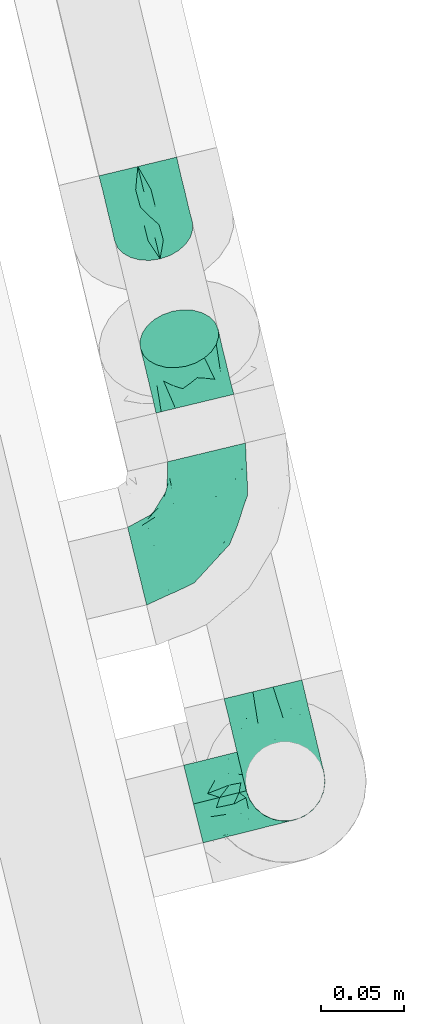
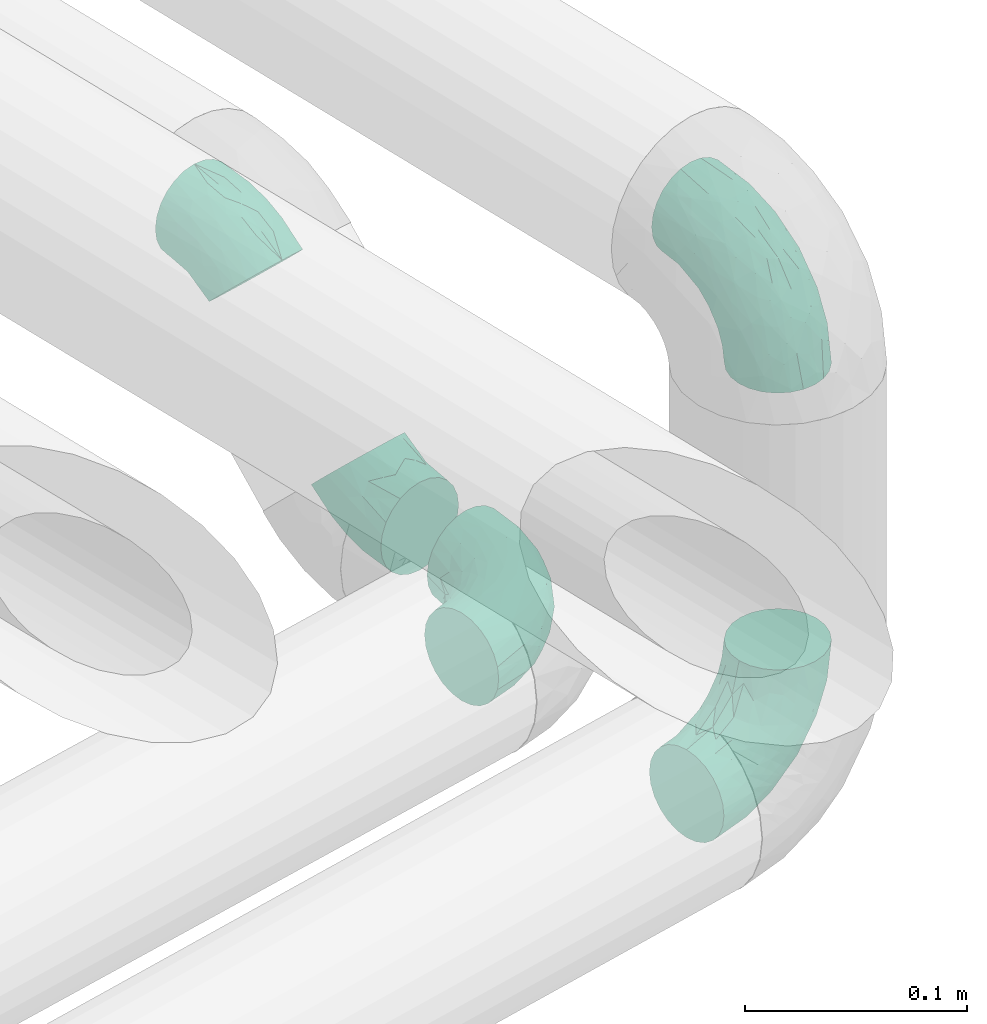
# One storey, part 50 of 93: 5 flow fittings.
"""IFC2X3 building model written with IfcOpenShell, lengths in millimetres."""

from ifc_helpers import new_model, entity, si_unit, converted_unit, derived_unit, direction, frame, origin, place, context, subcontext, project, spatial, faceted_brep, source, transform, mapped, material, type_object, type_shapes, element, save


model = new_model("IFC2X3")

# Units and contexts
model_context = context("Model", 3, precision=0.01, world=origin(), true_north=direction((6.12303176911189e-17, 1.0)))
body_context = subcontext(model_context, "Body", "Model", "MODEL_VIEW")
ifc_project = project(units=[si_unit("LENGTHUNIT", "METRE", prefix="MILLI"), si_unit("AREAUNIT", "SQUARE_METRE"), si_unit("VOLUMEUNIT", "CUBIC_METRE"), converted_unit("PLANEANGLEUNIT", "DEGREE", entity("IfcRatioMeasure", 0.0174532925199433), si_unit("PLANEANGLEUNIT", "RADIAN"), dimensions=[0, 0, 0, 0, 0, 0, 0]), si_unit("MASSUNIT", "GRAM", prefix="KILO"), derived_unit("MASSDENSITYUNIT", [(si_unit("MASSUNIT", "GRAM", prefix="KILO"), 1), (si_unit("LENGTHUNIT", "METRE"), -3)]), derived_unit("MOMENTOFINERTIAUNIT", [(si_unit("LENGTHUNIT", "METRE"), 4)]), si_unit("TIMEUNIT", "SECOND"), si_unit("FREQUENCYUNIT", "HERTZ"), si_unit("THERMODYNAMICTEMPERATUREUNIT", "DEGREE_CELSIUS"), derived_unit("THERMALTRANSMITTANCEUNIT", [(si_unit("MASSUNIT", "GRAM", prefix="KILO"), 1), (si_unit("THERMODYNAMICTEMPERATUREUNIT", "KELVIN"), -1), (si_unit("TIMEUNIT", "SECOND"), -3)]), derived_unit("VOLUMETRICFLOWRATEUNIT", [(si_unit("LENGTHUNIT", "METRE"), 3), (si_unit("TIMEUNIT", "SECOND"), -1)]), derived_unit("MASSFLOWRATEUNIT", [(si_unit("MASSUNIT", "GRAM", prefix="KILO"), 1), (si_unit("TIMEUNIT", "SECOND"), -1)]), derived_unit("ROTATIONALFREQUENCYUNIT", [(si_unit("TIMEUNIT", "SECOND"), -1)]), si_unit("ELECTRICCURRENTUNIT", "AMPERE"), si_unit("ELECTRICVOLTAGEUNIT", "VOLT"), si_unit("POWERUNIT", "WATT"), si_unit("FORCEUNIT", "NEWTON", prefix="KILO"), si_unit("ILLUMINANCEUNIT", "LUX"), si_unit("LUMINOUSFLUXUNIT", "LUMEN"), si_unit("LUMINOUSINTENSITYUNIT", "CANDELA"), derived_unit("USERDEFINED", [(si_unit("MASSUNIT", "GRAM", prefix="KILO"), -1), (si_unit("LENGTHUNIT", "METRE"), -2), (si_unit("TIMEUNIT", "SECOND"), 3), (si_unit("LUMINOUSFLUXUNIT", "LUMEN"), 1)]), derived_unit("LINEARVELOCITYUNIT", [(si_unit("LENGTHUNIT", "METRE"), 1), (si_unit("TIMEUNIT", "SECOND"), -1)]), si_unit("PRESSUREUNIT", "PASCAL"), derived_unit("USERDEFINED", [(si_unit("LENGTHUNIT", "METRE"), -2), (si_unit("MASSUNIT", "GRAM", prefix="KILO"), 1), (si_unit("TIMEUNIT", "SECOND"), -2)]), derived_unit("LINEARFORCEUNIT", [(si_unit("MASSUNIT", "GRAM", prefix="KILO"), 1), (si_unit("LENGTHUNIT", "METRE"), 1), (si_unit("TIMEUNIT", "SECOND"), -2), (si_unit("LENGTHUNIT", "METRE"), -1)]), derived_unit("PLANARFORCEUNIT", [(si_unit("MASSUNIT", "GRAM", prefix="KILO"), 1), (si_unit("LENGTHUNIT", "METRE"), 1), (si_unit("TIMEUNIT", "SECOND"), -2), (si_unit("LENGTHUNIT", "METRE"), -2)])], contexts=[model_context])

# Site, building, storey
site_placement = place(None, origin())
site = spatial("IfcSite", under=ifc_project, at=site_placement, CompositionType="ELEMENT")
building_placement = place(site_placement, origin())
building = spatial("IfcBuilding", under=site, at=building_placement, CompositionType="ELEMENT")
storey_placement = place(building_placement, frame((0.0, 0.0, -4200.0)))
storey = spatial("IfcBuildingStorey", under=building, at=storey_placement, CompositionType="ELEMENT", Elevation=-4200.0)

# Flow fittings
ifc_material = material()
pipe_fitting_type_1 = type_object("IfcPipeFittingType", Name="ADSK_1", PredefinedType="NOTDEFINED", material=ifc_material)
shared_shape_1 = source(origin(), body_context, "Body", "Brep", [
    faceted_brep([(-23.61, 12.07, -20.91), (-23.61, 6.25, -23.33), (-23.61, 0.0, -24.15), (-23.61, -6.25, -23.33), (-23.61, -12.08, -20.91), (-23.61, -17.08, -17.08), (-23.61, -20.91, -12.08), (-23.61, -23.33, -6.25), (-23.61, -24.15, 0.0), (-23.61, -23.33, 6.25), (-23.61, -20.91, 12.07), (-23.61, -17.08, 17.08), (-23.61, -12.08, 20.91), (-23.61, -6.25, 23.33), (-23.61, 0.0, 24.15), (-23.61, 6.25, 23.33), (-23.61, 12.07, 20.91), (-23.61, 17.08, 17.08), (-23.61, 20.91, 12.07), (-23.61, 23.33, 6.25), (-23.61, 24.15, 0.0), (-23.61, 23.33, -6.25), (-23.61, 20.91, -12.08), (-23.61, 17.08, -17.08), (16.69, 16.69, -24.15), (12.28, 21.11, -23.33), (8.16, 25.23, -20.91), (4.62, 28.77, -17.08), (1.91, 31.48, -12.08), (0.2, 33.19, -6.25), (-0.38, 33.77, 0.0), (0.2, 33.19, 6.25), (1.91, 31.48, 12.07), (4.62, 28.77, 17.08), (8.16, 25.23, 20.91), (12.28, 21.11, 23.33), (16.69, 16.69, 24.15), (21.11, 12.28, 23.33), (25.23, 8.16, 20.91), (28.77, 4.62, 17.08), (31.48, 1.91, 12.07), (33.19, 0.2, 6.25), (33.77, -0.38, 0.0), (33.19, 0.2, -6.25), (31.48, 1.91, -12.08), (28.77, 4.62, -17.08), (25.23, 8.16, -20.91), (21.11, 12.28, -23.33), (-9.66, -18.22, 14.24), (2.13, -5.14, 21.86), (-11.69, -8.63, 22.11), (-6.72, -13.25, 18.72), (19.71, -6.06, 14.24), (-8.6, -1.92, 23.85), (-10.69, 10.43, 22.54), (-2.63, 6.36, 24.05), (-14.22, 3.55, 24.0), (7.54, 12.56, 24.0), (-5.72, -20.55, 8.53), (5.82, -14.04, 13.69), (14.37, 2.16, 22.11), (-10.23, 24.7, 9.87), (-12.1, 20.57, 15.16), (-7.17, 17.31, 19.65), (13.57, -14.71, 4.23), (6.78, -16.37, 8.99), (2.14, -19.5, 4.58), (-8.08, -21.06, 0.0), (-8.37, -22.29, 4.45), (23.21, -8.75, 4.57), (18.58, -10.49, 8.53), (-8.68, 27.14, 5.05), (-3.47, 22.63, 16.99), (7.44, 4.72, 23.85), (14.13, -4.62, 18.72), (7.44, -17.97, 0.0), (1.54, 15.81, 22.51), (-11.04, 26.65, 0.0), (3.66, -8.83, 19.49), (20.61, -9.18, 0.0), (-8.6, -1.92, -23.85), (0.81, -20.0, -4.23), (6.78, -16.37, -8.99), (12.28, -15.3, -4.58), (0.18, 14.93, -22.54), (-14.22, 3.55, -24.0), (-13.06, 25.33, -5.05), (-10.23, 24.7, -9.87), (14.13, -4.62, -18.72), (-13.55, 18.45, -16.99), (18.58, -10.49, -8.53), (-5.99, 23.1, -15.16), (7.44, 4.72, -23.85), (-10.22, -22.6, -4.57), (-5.72, -20.55, -8.53), (-12.27, 10.09, -22.51), (-9.66, -18.22, -14.24), (5.82, -14.04, -13.69), (-6.72, -13.25, -18.72), (3.66, -8.83, -19.49), (-11.69, -8.63, -22.11), (2.13, -5.14, -21.86), (-7.17, 17.31, -19.65), (21.68, -9.84, -4.45), (7.54, 12.56, -24.0), (14.37, 2.16, -22.11), (19.71, -6.06, -14.24), (-2.63, 6.36, -24.05)], [[[0, 1, 2, 3, 4, 5, 6, 7, 8, 9, 10, 11, 12, 13, 14, 15, 16, 17, 18, 19, 20, 21, 22, 23]], [[24, 25, 26, 27, 28, 29, 30, 31, 32, 33, 34, 35, 36, 37, 38, 39, 40, 41, 42, 43, 44, 45, 46, 47]], [[10, 48, 11]], [[49, 50, 51]], [[12, 11, 51]], [[40, 39, 52]], [[14, 13, 53]], [[13, 12, 50]], [[16, 15, 54]], [[55, 56, 53]], [[14, 56, 15]], [[36, 35, 57]], [[48, 58, 59]], [[38, 37, 60]], [[61, 18, 62]], [[63, 17, 16]], [[64, 65, 66]], [[67, 66, 68]], [[69, 70, 64]], [[61, 71, 19]], [[10, 9, 58]], [[20, 19, 71]], [[19, 18, 61]], [[48, 51, 11]], [[54, 63, 16]], [[58, 65, 59]], [[8, 67, 68]], [[33, 72, 34]], [[36, 57, 73]], [[39, 38, 74]], [[49, 73, 53]], [[73, 37, 36]], [[66, 67, 75]], [[70, 40, 52]], [[55, 57, 76]], [[74, 38, 60]], [[58, 48, 10]], [[64, 70, 65]], [[41, 69, 42]], [[56, 54, 15]], [[71, 61, 31]], [[77, 71, 30]], [[52, 74, 59]], [[51, 78, 49]], [[49, 60, 73]], [[35, 34, 76]], [[32, 31, 61]], [[61, 62, 32]], [[50, 53, 13]], [[32, 62, 72]], [[63, 54, 76]], [[18, 17, 62]], [[55, 53, 73]], [[41, 40, 70]], [[51, 48, 59]], [[78, 59, 74]], [[74, 52, 39]], [[70, 52, 59]], [[17, 63, 62]], [[72, 62, 63]], [[63, 76, 34]], [[55, 76, 54]], [[51, 50, 12]], [[53, 50, 49]], [[73, 60, 37]], [[74, 60, 49]], [[53, 56, 14]], [[54, 56, 55]], [[76, 57, 35]], [[73, 57, 55]], [[66, 65, 58]], [[70, 59, 65]], [[66, 58, 68]], [[66, 75, 64]], [[75, 79, 64]], [[69, 64, 79]], [[42, 69, 79]], [[41, 70, 69]], [[58, 9, 68]], [[8, 68, 9]], [[59, 78, 51]], [[74, 49, 78]], [[30, 71, 31]], [[71, 77, 20]], [[34, 72, 63]], [[32, 72, 33]], [[3, 2, 80]], [[81, 82, 83]], [[26, 25, 84]], [[2, 1, 85]], [[21, 86, 87]], [[46, 45, 88]], [[0, 23, 89]], [[44, 43, 90]], [[91, 89, 22]], [[24, 47, 92]], [[93, 94, 81]], [[1, 0, 95]], [[81, 94, 82]], [[94, 96, 97]], [[7, 93, 8]], [[96, 94, 6]], [[5, 4, 98]], [[99, 97, 98]], [[7, 6, 94]], [[5, 96, 6]], [[100, 4, 3]], [[28, 27, 91]], [[83, 79, 75]], [[88, 99, 101]], [[20, 77, 86]], [[98, 96, 5]], [[30, 29, 86]], [[29, 28, 87]], [[102, 84, 95]], [[87, 22, 21]], [[28, 91, 87]], [[100, 98, 4]], [[84, 102, 26]], [[87, 91, 22]], [[85, 80, 2]], [[27, 26, 102]], [[79, 83, 103]], [[24, 104, 25]], [[105, 47, 46]], [[90, 82, 97]], [[106, 88, 45]], [[88, 101, 105]], [[90, 97, 106]], [[101, 80, 92]], [[42, 79, 103]], [[101, 100, 80]], [[107, 92, 80]], [[106, 45, 44]], [[96, 98, 97]], [[104, 92, 107]], [[104, 84, 25]], [[29, 87, 86]], [[107, 85, 95]], [[105, 92, 47]], [[90, 106, 44]], [[88, 106, 97]], [[27, 102, 91]], [[89, 91, 102]], [[102, 95, 0]], [[107, 95, 84]], [[80, 100, 3]], [[98, 100, 101]], [[88, 105, 46]], [[92, 105, 101]], [[95, 85, 1]], [[80, 85, 107]], [[92, 104, 24]], [[84, 104, 107]], [[83, 82, 90]], [[94, 97, 82]], [[83, 90, 103]], [[83, 75, 81]], [[75, 67, 81]], [[93, 81, 67]], [[8, 93, 67]], [[7, 94, 93]], [[90, 43, 103]], [[42, 103, 43]], [[97, 99, 88]], [[98, 101, 99]], [[20, 86, 21]], [[86, 77, 30]], [[0, 89, 102]], [[22, 89, 23]]]),
])
type_shapes(pipe_fitting_type_1, [shared_shape_1])
for number, where, z_axis, x_axis, name in (
    (1, (-14622.8, 9926.54, 2292.84), (0.972268264557654, 0.233868385495023, 0.0), (-0.233868385495023, 0.972268264557654, 0.0), "ADSK_1"),
    (2, (-14646.19, 10023.77, 2392.84), (-0.972268264557591, -0.233868385495284, 0.0), (-0.165369921288827, 0.687497483001099, 0.707106781186605), "ADSK_1"),
):
    element("IfcFlowFitting", number, at=place(storey_placement, frame(where, z_axis=z_axis, x_axis=x_axis)), inside=storey, type_object=pipe_fitting_type_1, material=ifc_material, Name=name, ObjectType="ADSK_1", context=body_context, shape_type="MappedRepresentation", body=[
        mapped(shared_shape_1, transform((0.0, 0.0, 0.0), scale=1.0)),
    ])
pipe_fitting_type_2 = type_object("IfcPipeFittingType", Name="ADSK_1", PredefinedType="NOTDEFINED", material=ifc_material)
shared_shape_2 = source(origin(), body_context, "Body", "Brep", [
    faceted_brep([(-57.0, 12.07, -20.91), (-57.0, 6.25, -23.33), (-57.0, 0.0, -24.15), (-57.0, -6.25, -23.33), (-57.0, -12.08, -20.91), (-57.0, -17.08, -17.08), (-57.0, -20.91, -12.08), (-57.0, -23.33, -6.25), (-57.0, -24.15, 0.0), (-57.0, -23.33, 6.25), (-57.0, -20.91, 12.07), (-57.0, -17.08, 17.08), (-57.0, -12.08, 20.91), (-57.0, -6.25, 23.33), (-57.0, 0.0, 24.15), (-57.0, 6.25, 23.33), (-57.0, 12.07, 20.91), (-57.0, 17.08, 17.08), (-57.0, 20.91, 12.07), (-57.0, 23.33, 6.25), (-57.0, 24.15, 0.0), (-57.0, 23.33, -6.25), (-57.0, 20.91, -12.08), (-57.0, 17.08, -17.08), (0.0, 57.0, -24.15), (-6.25, 57.0, -23.33), (-12.07, 57.0, -20.91), (-17.08, 57.0, -17.08), (-20.91, 57.0, -12.08), (-23.33, 57.0, -6.25), (-24.15, 57.0, 0.0), (-23.33, 57.0, 6.25), (-20.91, 57.0, 12.07), (-17.08, 57.0, 17.08), (-12.07, 57.0, 20.91), (-6.25, 57.0, 23.33), (0.0, 57.0, 24.15), (6.25, 57.0, 23.33), (12.08, 57.0, 20.91), (17.08, 57.0, 17.08), (20.91, 57.0, 12.07), (23.33, 57.0, 6.25), (24.15, 57.0, 0.0), (23.33, 57.0, -6.25), (20.91, 57.0, -12.08), (17.08, 57.0, -17.08), (12.08, 57.0, -20.91), (6.25, 57.0, -23.33), (14.9, 21.14, 6.17), (13.61, 24.64, 12.48), (6.23, 8.95, 8.98), (-41.47, -21.06, 0.0), (-41.92, -18.38, 13.72), (-24.64, -13.61, 12.48), (-37.37, -13.24, 18.15), (-6.8, -4.93, 8.18), (-21.76, -15.19, 6.22), (-12.78, -9.18, 0.0), (-37.73, -20.51, 7.75), (-7.38, 7.38, 20.24), (-23.37, -4.26, 20.42), (-11.9, -3.19, 15.86), (-42.14, -8.7, 21.82), (13.24, 37.37, 18.15), (9.33, 23.53, 16.85), (4.26, 23.37, 20.42), (2.77, 10.92, 15.55), (-29.46, 0.91, 23.52), (-44.13, 20.56, 15.69), (-39.25, 26.33, 10.88), (-49.02, 22.92, 9.96), (-34.58, 23.87, 17.15), (-15.8, 6.8, 22.81), (-8.67, 20.47, 23.88), (-18.12, 12.9, 24.08), (-48.29, 14.92, 19.65), (-44.06, -2.85, 23.78), (-9.23, 48.95, 22.58), (-3.78, 42.74, 24.07), (-40.34, 4.26, 24.09), (-44.02, 26.14, 5.46), (-44.04, 9.88, 22.74), (-4.95, 16.87, 22.52), (-2.75, 1.43, 12.5), (-25.48, 40.98, 10.71), (20.51, 37.73, 7.75), (18.38, 41.92, 13.72), (8.7, 42.14, 21.82), (-25.95, -17.97, 0.0), (2.85, 44.06, 23.78), (21.06, 41.47, 0.0), (17.97, 25.95, 0.0), (-24.04, -9.27, 17.13), (-33.26, 33.26, 5.86), (-28.55, 40.57, 0.0), (-40.57, 28.55, 0.0), (-25.29, 47.19, 4.06), (-27.01, 31.1, 16.77), (-15.7, 43.95, 19.9), (-20.27, 45.22, 15.61), (-30.53, 31.98, 12.64), (-11.28, 38.33, 22.92), (-9.97, 27.88, 24.09), (-20.15, 30.26, 21.25), (-31.25, 11.75, 23.64), (-28.75, 7.23, 24.15), (-29.53, 18.06, 22.27), (-28.44, 24.21, 20.02), (-37.55, 17.7, 20.26), (-15.88, 29.25, 22.99), (-20.82, 20.82, 23.44), (-0.91, 29.46, 23.52), (-13.5, -7.67, 12.04), (1.49, 1.56, 5.16), (8.86, 10.35, 4.59), (0.38, -0.38, 0.0), (9.18, 12.78, 0.0), (-37.37, -13.24, -18.15), (8.86, 10.35, -4.59), (-45.22, 20.27, -15.61), (-43.95, 15.7, -19.9), (-38.33, 11.28, -22.92), (-48.95, 9.23, -22.58), (-47.19, 25.29, -4.06), (-33.26, 33.26, -5.86), (18.38, 41.92, -13.72), (-30.26, 20.15, -21.25), (2.85, 44.06, -23.78), (-4.26, 40.34, -24.09), (-40.98, 25.48, -10.71), (-41.92, -18.38, -13.72), (9.25, 23.5, -16.92), (4.26, 23.37, -20.42), (13.24, 37.37, -18.15), (-37.73, -20.51, -7.75), (-11.75, 31.25, -23.64), (-7.23, 28.75, -24.15), (-12.9, 18.12, -24.08), (8.7, 42.14, -21.82), (-44.06, -2.85, -23.78), (-6.8, 15.8, -22.81), (-20.47, 8.67, -23.88), (-24.64, -13.61, -12.48), (-42.74, 3.78, -24.07), (-18.06, 29.53, -22.27), (-24.21, 28.44, -20.02), (-27.88, 9.97, -24.09), (-31.1, 27.01, -16.77), (-26.14, 44.02, -5.46), (14.9, 21.14, -6.17), (20.51, 37.73, -7.75), (-9.88, 44.04, -22.74), (-20.56, 44.13, -15.69), (-21.76, -15.19, -6.22), (-13.5, -7.67, -12.04), (-24.14, -9.76, -16.74), (-11.9, -3.19, -15.86), (-14.92, 48.29, -19.65), (-23.37, -4.26, -20.42), (-0.91, 29.46, -23.52), (-26.33, 39.25, -10.88), (-23.87, 34.58, -17.15), (-42.14, -8.7, -21.82), (-22.92, 49.02, -9.96), (13.61, 24.64, -12.48), (-31.98, 30.53, -12.64), (-16.87, 4.95, -22.52), (-17.7, 37.55, -20.26), (-29.25, 15.88, -22.99), (-20.82, 20.82, -23.44), (-29.46, 0.91, -23.52), (-7.38, 7.38, -20.24), (2.77, 10.92, -15.55), (6.23, 8.95, -8.98), (-6.8, -4.93, -8.18), (-2.81, 1.41, -12.54), (1.49, 1.56, -5.16)], [[[0, 1, 2, 3, 4, 5, 6, 7, 8, 9, 10, 11, 12, 13, 14, 15, 16, 17, 18, 19, 20, 21, 22, 23]], [[24, 25, 26, 27, 28, 29, 30, 31, 32, 33, 34, 35, 36, 37, 38, 39, 40, 41, 42, 43, 44, 45, 46, 47]], [[48, 49, 50]], [[9, 8, 51]], [[52, 53, 54]], [[55, 56, 57]], [[10, 58, 52]], [[9, 58, 10]], [[59, 60, 61]], [[54, 12, 11]], [[54, 62, 12]], [[63, 39, 38]], [[64, 65, 66]], [[62, 60, 67]], [[68, 69, 70]], [[71, 69, 68]], [[72, 73, 74]], [[16, 75, 17]], [[13, 76, 14]], [[35, 77, 78]], [[14, 79, 15]], [[17, 68, 18]], [[14, 76, 79]], [[20, 19, 80]], [[70, 19, 18]], [[81, 15, 79]], [[15, 81, 16]], [[73, 72, 82]], [[66, 83, 50]], [[32, 31, 84]], [[85, 86, 49]], [[63, 87, 65]], [[56, 58, 88]], [[36, 89, 37]], [[85, 41, 40]], [[36, 35, 78]], [[90, 41, 85]], [[40, 39, 86]], [[12, 62, 13]], [[86, 85, 40]], [[48, 85, 49]], [[85, 91, 90]], [[87, 38, 37]], [[92, 60, 54]], [[80, 69, 93]], [[93, 94, 95]], [[10, 52, 11]], [[94, 96, 30]], [[97, 98, 99]], [[80, 93, 95]], [[100, 97, 84]], [[99, 98, 33]], [[101, 102, 78]], [[103, 101, 98]], [[96, 31, 30]], [[77, 98, 101]], [[77, 35, 34]], [[34, 33, 98]], [[9, 51, 58]], [[87, 63, 38]], [[104, 105, 74]], [[106, 103, 107]], [[106, 81, 104]], [[75, 68, 17]], [[108, 107, 71]], [[33, 32, 99]], [[109, 103, 110]], [[101, 109, 102]], [[89, 78, 111]], [[53, 52, 58]], [[54, 11, 52]], [[60, 62, 54]], [[88, 58, 51]], [[76, 62, 67]], [[53, 112, 92]], [[60, 59, 72]], [[39, 63, 86]], [[49, 86, 63]], [[89, 87, 37]], [[42, 41, 90]], [[111, 82, 65]], [[111, 65, 87]], [[65, 59, 66]], [[104, 81, 79]], [[75, 81, 108]], [[32, 84, 99]], [[97, 99, 84]], [[98, 97, 103]], [[106, 107, 108]], [[74, 102, 110]], [[111, 78, 102]], [[74, 110, 104]], [[74, 67, 72]], [[61, 92, 112]], [[66, 59, 61]], [[56, 53, 58]], [[66, 50, 49]], [[61, 112, 83]], [[66, 49, 64]], [[78, 89, 36]], [[87, 89, 111]], [[62, 76, 13]], [[79, 76, 67]], [[100, 93, 69]], [[96, 93, 84]], [[55, 113, 50]], [[113, 114, 50]], [[104, 79, 105]], [[106, 104, 110]], [[20, 80, 95]], [[85, 48, 91]], [[115, 114, 113]], [[116, 91, 48]], [[70, 80, 19]], [[93, 96, 94]], [[84, 31, 96]], [[103, 106, 110]], [[81, 106, 108]], [[103, 97, 107]], [[71, 107, 97]], [[71, 97, 100]], [[108, 71, 68]], [[79, 67, 105]], [[67, 74, 105]], [[115, 113, 57]], [[112, 56, 55]], [[56, 88, 57]], [[60, 72, 67]], [[82, 72, 59]], [[65, 82, 59]], [[82, 111, 73]], [[111, 102, 73]], [[102, 74, 73]], [[81, 75, 16]], [[68, 75, 108]], [[68, 70, 18]], [[80, 70, 69]], [[98, 77, 34]], [[78, 77, 101]], [[93, 100, 84]], [[71, 100, 69]], [[102, 109, 110]], [[101, 103, 109]], [[53, 92, 54]], [[61, 60, 92]], [[56, 112, 53]], [[83, 112, 55]], [[50, 83, 55]], [[61, 83, 66]], [[49, 63, 64]], [[65, 64, 63]], [[57, 113, 55]], [[114, 115, 116]], [[116, 48, 114]], [[48, 50, 114]], [[117, 5, 4]], [[116, 115, 118]], [[119, 120, 23]], [[121, 122, 120]], [[95, 123, 20]], [[0, 23, 120]], [[124, 95, 94]], [[125, 45, 44]], [[121, 120, 126]], [[24, 127, 128]], [[22, 21, 129]], [[0, 122, 1]], [[5, 117, 130]], [[131, 132, 133]], [[134, 88, 51]], [[135, 136, 137]], [[6, 5, 130]], [[46, 138, 47]], [[139, 3, 2]], [[140, 141, 137]], [[6, 134, 7]], [[134, 130, 142]], [[143, 2, 1]], [[144, 126, 145]], [[121, 146, 143]], [[147, 120, 119]], [[94, 148, 124]], [[149, 150, 91]], [[30, 29, 148]], [[151, 25, 128]], [[27, 152, 28]], [[134, 153, 88]], [[154, 155, 156]], [[27, 26, 157]], [[151, 26, 25]], [[155, 158, 156]], [[24, 47, 127]], [[1, 122, 143]], [[138, 132, 159]], [[160, 152, 161]], [[24, 128, 25]], [[46, 133, 138]], [[162, 117, 4]], [[148, 160, 124]], [[152, 160, 163]], [[154, 142, 155]], [[45, 125, 133]], [[133, 46, 45]], [[125, 164, 133]], [[51, 7, 134]], [[42, 90, 43]], [[165, 147, 129]], [[153, 134, 142]], [[43, 150, 44]], [[162, 4, 3]], [[141, 140, 166]], [[117, 162, 158]], [[163, 29, 28]], [[43, 90, 150]], [[123, 21, 20]], [[144, 151, 135]], [[157, 152, 27]], [[167, 145, 161]], [[23, 22, 119]], [[168, 126, 169]], [[121, 168, 146]], [[139, 143, 170]], [[142, 130, 117]], [[8, 7, 51]], [[134, 6, 130]], [[139, 162, 3]], [[170, 166, 158]], [[170, 158, 162]], [[158, 171, 156]], [[44, 150, 125]], [[91, 150, 90]], [[164, 125, 150]], [[132, 138, 133]], [[127, 138, 159]], [[131, 164, 172]], [[132, 171, 140]], [[135, 151, 128]], [[157, 151, 167]], [[22, 129, 119]], [[147, 119, 129]], [[120, 147, 126]], [[144, 145, 167]], [[137, 146, 169]], [[170, 143, 146]], [[137, 169, 135]], [[137, 159, 140]], [[171, 172, 156]], [[173, 174, 175]], [[156, 175, 154]], [[174, 57, 153]], [[132, 172, 171]], [[172, 164, 173]], [[143, 139, 2]], [[162, 139, 170]], [[138, 127, 47]], [[128, 127, 159]], [[165, 124, 160]], [[123, 124, 129]], [[149, 173, 164]], [[176, 174, 173]], [[135, 128, 136]], [[144, 135, 169]], [[150, 149, 164]], [[176, 118, 115]], [[149, 91, 116]], [[30, 148, 94]], [[163, 148, 29]], [[124, 123, 95]], [[129, 21, 123]], [[126, 144, 169]], [[151, 144, 167]], [[126, 147, 145]], [[161, 145, 147]], [[161, 147, 165]], [[167, 161, 152]], [[128, 159, 136]], [[159, 137, 136]], [[154, 153, 142]], [[132, 140, 159]], [[174, 176, 57]], [[57, 88, 153]], [[166, 140, 171]], [[158, 166, 171]], [[166, 170, 141]], [[170, 146, 141]], [[146, 137, 141]], [[151, 157, 26]], [[152, 157, 167]], [[152, 163, 28]], [[148, 163, 160]], [[120, 122, 0]], [[143, 122, 121]], [[124, 165, 129]], [[161, 165, 160]], [[146, 168, 169]], [[121, 126, 168]], [[142, 117, 155]], [[158, 155, 117]], [[175, 156, 172]], [[153, 154, 174]], [[173, 175, 172]], [[174, 154, 175]], [[164, 131, 133]], [[172, 132, 131]], [[176, 173, 118]], [[57, 176, 115]], [[173, 149, 118]], [[149, 116, 118]]]),
])
type_shapes(pipe_fitting_type_2, [shared_shape_2])
for number, where, z_axis, x_axis, name in (
    (3, (-14562.88, 9675.8, 2292.84), (0.241921895599571, -0.970295726276021, 0.0), (0.970295726276021, 0.241921895599571, 0.0), "ADSK_1"),
    (4, (-14562.88, 9675.8, 2558.8), (-0.9723215569699, -0.233646720181624, 0.0), (0.0, 0.0, 1.0), "ADSK_1"),
):
    element("IfcFlowFitting", number, at=place(storey_placement, frame(where, z_axis=z_axis, x_axis=x_axis)), inside=storey, type_object=pipe_fitting_type_2, material=ifc_material, Name=name, ObjectType="ADSK_1", context=body_context, shape_type="MappedRepresentation", body=[
        mapped(shared_shape_2, transform((0.0, 0.0, 0.0), scale=1.0)),
    ])
pipe_fitting_type_3 = type_object("IfcPipeFittingType", Name="ADSK_1", PredefinedType="NOTDEFINED", material=ifc_material)
shared_shape_3 = source(origin(), body_context, "Body", "Brep", [
    faceted_brep([(-56.83, 12.07, -20.91), (-56.83, 6.25, -23.33), (-56.83, 0.0, -24.15), (-56.83, -6.25, -23.33), (-56.83, -12.08, -20.91), (-56.83, -17.08, -17.08), (-56.83, -20.91, -12.08), (-56.83, -23.33, -6.25), (-56.83, -24.15, 0.0), (-56.83, -23.33, 6.25), (-56.83, -20.91, 12.07), (-56.83, -17.08, 17.08), (-56.83, -12.08, 20.91), (-56.83, -6.25, 23.33), (-56.83, 0.0, 24.15), (-56.83, 6.25, 23.33), (-56.83, 12.07, 20.91), (-56.83, 17.08, 17.08), (-56.83, 20.91, 12.07), (-56.83, 23.33, 6.25), (-56.83, 24.15, 0.0), (-56.83, 23.33, -6.25), (-56.83, 20.91, -12.08), (-56.83, 17.08, -17.08), (0.17, 56.83, -24.15), (-6.08, 56.85, -23.33), (-11.9, 56.86, -20.91), (-16.9, 56.88, -17.08), (-20.74, 56.89, -12.08), (-23.15, 56.9, -6.25), (-23.98, 56.9, 0.0), (-23.15, 56.9, 6.25), (-20.74, 56.89, 12.07), (-16.9, 56.88, 17.08), (-11.9, 56.86, 20.91), (-6.08, 56.85, 23.33), (0.17, 56.83, 24.15), (6.42, 56.81, 23.33), (12.25, 56.79, 20.91), (17.25, 56.78, 17.08), (21.09, 56.76, 12.07), (23.5, 56.76, 6.25), (24.32, 56.75, 0.0), (23.5, 56.76, -6.25), (21.09, 56.76, -12.08), (17.25, 56.78, -17.08), (12.25, 56.79, -20.91), (6.42, 56.81, -23.33), (20.62, 37.48, 7.75), (15.96, 22.81, 5.91), (18.07, 25.77, 0.0), (-41.33, -21.07, 0.0), (-41.75, -18.38, 13.72), (-24.45, -13.6, 12.49), (-37.19, -13.24, 18.15), (-6.58, -4.88, 8.21), (-21.57, -15.18, 6.21), (-12.68, -9.23, 0.0), (-37.55, -20.51, 7.75), (-7.3, 7.32, 20.25), (-23.25, -4.29, 20.43), (-11.79, -3.22, 15.88), (-41.97, -8.7, 21.82), (13.35, 37.15, 18.15), (9.44, 23.39, 16.85), (4.36, 23.23, 20.43), (2.85, 10.83, 15.59), (-29.33, 0.9, 23.52), (-43.97, 20.56, 15.69), (-39.11, 26.31, 10.88), (-48.87, 22.92, 9.95), (-34.46, 23.82, 17.17), (-15.68, 6.79, 22.82), (-8.58, 20.35, 23.88), (-18.04, 12.86, 24.09), (-48.15, 14.92, 19.65), (-43.91, -2.85, 23.78), (-9.08, 48.83, 22.58), (-3.65, 42.59, 24.07), (-40.18, 4.26, 24.09), (-43.89, 26.12, 5.46), (-43.87, 9.88, 22.74), (-4.83, 16.8, 22.52), (-2.62, 1.41, 12.53), (8.01, 9.81, 6.74), (5.98, 10.29, 11.43), (-25.36, 40.89, 10.71), (18.51, 41.69, 13.72), (13.68, 24.41, 12.49), (-30.4, 31.93, 12.64), (-26.91, 31.03, 16.77), (2.98, 43.91, 23.78), (8.82, 41.95, 21.82), (21.2, 41.26, 0.0), (-25.14, 47.11, 4.05), (-33.12, 33.23, 5.86), (-28.41, 40.52, 0.0), (-40.43, 28.53, 0.0), (-15.57, 43.84, 19.9), (-20.14, 45.11, 15.61), (-25.83, -18.0, 0.0), (-11.16, 38.23, 22.91), (-9.88, 27.8, 24.09), (-20.02, 30.2, 21.25), (-23.9, -9.27, 17.15), (-31.12, 11.73, 23.64), (-28.63, 7.22, 24.15), (-29.42, 18.02, 22.27), (-28.31, 24.17, 20.02), (-37.43, 17.68, 20.25), (-15.76, 29.17, 22.99), (-20.71, 20.77, 23.43), (-0.81, 29.33, 23.52), (-13.32, -7.65, 12.06), (0.47, -0.47, 0.0), (9.27, 12.65, 0.0), (-37.19, -13.24, -18.15), (15.73, 22.93, -6.86), (8.01, 9.81, -6.74), (-45.05, 20.27, -15.61), (-43.79, 15.7, -19.9), (-38.2, 11.27, -22.91), (-48.8, 9.23, -22.58), (-47.03, 25.29, -4.05), (-33.12, 33.23, -5.86), (18.51, 41.69, -13.72), (-30.14, 20.11, -21.25), (2.98, 43.91, -23.78), (-4.14, 40.2, -24.09), (-40.81, 25.48, -10.71), (-41.75, -18.38, -13.72), (-37.55, -20.51, -7.75), (-11.63, 31.15, -23.64), (-7.14, 28.66, -24.15), (-12.8, 18.08, -24.09), (-31.84, 30.5, -12.64), (-30.94, 27.01, -16.77), (-43.91, -2.85, -23.78), (-6.74, 15.7, -22.82), (-20.33, 8.64, -23.88), (-24.45, -13.6, -12.49), (-42.58, 3.78, -24.07), (-17.93, 29.48, -22.27), (-24.08, 28.38, -20.02), (-27.77, 9.96, -24.09), (-25.99, 43.97, -5.46), (8.82, 41.95, -21.82), (-9.75, 43.9, -22.74), (-20.43, 44.03, -15.69), (-21.57, -15.18, -6.21), (-13.32, -7.65, -12.06), (-24.0, -9.78, -16.74), (-11.79, -3.22, -15.88), (-14.78, 48.19, -19.65), (-23.25, -4.29, -20.43), (4.36, 23.23, -20.43), (-0.81, 29.33, -23.52), (-26.19, 39.19, -10.88), (-23.72, 34.53, -17.17), (13.35, 37.15, -18.15), (-41.97, -8.7, -21.82), (-22.77, 48.94, -9.95), (13.68, 24.41, -12.49), (20.62, 37.48, -7.75), (-16.78, 4.88, -22.52), (5.98, 10.29, -11.43), (9.32, 23.35, -16.94), (-17.57, 37.48, -20.25), (-29.13, 15.85, -22.99), (-20.71, 20.77, -23.43), (-29.33, 0.9, -23.52), (-7.3, 7.32, -20.25), (2.85, 10.83, -15.59), (-6.58, -4.88, -8.21), (-2.62, 1.41, -12.53)], [[[0, 1, 2, 3, 4, 5, 6, 7, 8, 9, 10, 11, 12, 13, 14, 15, 16, 17, 18, 19, 20, 21, 22, 23]], [[24, 25, 26, 27, 28, 29, 30, 31, 32, 33, 34, 35, 36, 37, 38, 39, 40, 41, 42, 43, 44, 45, 46, 47]], [[48, 49, 50]], [[9, 8, 51]], [[52, 53, 54]], [[55, 56, 57]], [[10, 58, 52]], [[9, 58, 10]], [[59, 60, 61]], [[54, 12, 11]], [[54, 62, 12]], [[63, 39, 38]], [[64, 65, 66]], [[62, 60, 67]], [[68, 69, 70]], [[71, 69, 68]], [[72, 73, 74]], [[16, 75, 17]], [[13, 76, 14]], [[35, 77, 78]], [[14, 79, 15]], [[17, 68, 18]], [[14, 76, 79]], [[20, 19, 80]], [[70, 19, 18]], [[81, 15, 79]], [[15, 81, 16]], [[73, 72, 82]], [[83, 84, 85]], [[32, 31, 86]], [[48, 87, 88]], [[89, 90, 86]], [[12, 62, 13]], [[36, 91, 37]], [[48, 41, 40]], [[36, 35, 78]], [[63, 92, 65]], [[40, 39, 87]], [[93, 41, 48]], [[87, 48, 40]], [[92, 38, 37]], [[48, 50, 93]], [[94, 31, 30]], [[49, 88, 84]], [[80, 69, 95]], [[95, 96, 97]], [[10, 52, 11]], [[96, 94, 30]], [[90, 98, 99]], [[80, 95, 97]], [[56, 58, 100]], [[99, 98, 33]], [[101, 102, 78]], [[103, 101, 98]], [[9, 51, 58]], [[77, 98, 101]], [[77, 35, 34]], [[34, 33, 98]], [[104, 60, 54]], [[92, 63, 38]], [[105, 106, 74]], [[107, 103, 108]], [[107, 81, 105]], [[75, 68, 17]], [[109, 108, 71]], [[33, 32, 99]], [[110, 103, 111]], [[101, 110, 102]], [[91, 78, 112]], [[53, 52, 58]], [[54, 11, 52]], [[60, 62, 54]], [[100, 58, 51]], [[76, 62, 67]], [[53, 113, 104]], [[60, 59, 72]], [[39, 63, 87]], [[88, 87, 63]], [[91, 92, 37]], [[42, 41, 93]], [[112, 82, 65]], [[112, 65, 92]], [[65, 59, 66]], [[105, 81, 79]], [[75, 81, 109]], [[32, 86, 99]], [[90, 99, 86]], [[98, 90, 103]], [[107, 108, 109]], [[74, 102, 111]], [[112, 78, 102]], [[74, 111, 105]], [[74, 67, 72]], [[61, 104, 113]], [[66, 59, 61]], [[56, 53, 58]], [[84, 55, 114]], [[61, 113, 83]], [[66, 88, 64]], [[78, 91, 36]], [[92, 91, 112]], [[62, 76, 13]], [[79, 76, 67]], [[89, 95, 69]], [[94, 95, 86]], [[84, 114, 115]], [[83, 85, 66]], [[105, 79, 106]], [[107, 105, 111]], [[20, 80, 97]], [[70, 80, 19]], [[103, 107, 111]], [[81, 107, 109]], [[103, 90, 108]], [[71, 108, 90]], [[71, 90, 89]], [[109, 71, 68]], [[95, 94, 96]], [[86, 31, 94]], [[79, 67, 106]], [[67, 74, 106]], [[57, 114, 55]], [[113, 56, 55]], [[56, 100, 57]], [[60, 72, 67]], [[82, 72, 59]], [[65, 82, 59]], [[82, 112, 73]], [[112, 102, 73]], [[102, 74, 73]], [[81, 75, 16]], [[68, 75, 109]], [[68, 70, 18]], [[80, 70, 69]], [[98, 77, 34]], [[78, 77, 101]], [[95, 89, 86]], [[71, 89, 69]], [[102, 110, 111]], [[101, 103, 110]], [[53, 104, 54]], [[61, 60, 104]], [[56, 113, 53]], [[83, 113, 55]], [[84, 83, 55]], [[61, 83, 66]], [[84, 88, 85]], [[88, 66, 85]], [[88, 63, 64]], [[65, 64, 63]], [[88, 49, 48]], [[49, 115, 50]], [[115, 49, 84]], [[116, 5, 4]], [[117, 115, 118]], [[119, 120, 23]], [[121, 122, 120]], [[97, 123, 20]], [[0, 23, 120]], [[124, 97, 96]], [[125, 45, 44]], [[121, 120, 126]], [[24, 127, 128]], [[22, 21, 129]], [[0, 122, 1]], [[5, 116, 130]], [[123, 21, 20]], [[131, 100, 51]], [[132, 133, 134]], [[6, 5, 130]], [[135, 136, 129]], [[137, 3, 2]], [[138, 139, 134]], [[6, 131, 7]], [[131, 130, 140]], [[141, 2, 1]], [[142, 126, 143]], [[121, 144, 141]], [[136, 120, 119]], [[96, 145, 124]], [[46, 146, 47]], [[30, 29, 145]], [[147, 25, 128]], [[27, 148, 28]], [[131, 149, 100]], [[150, 151, 152]], [[27, 26, 153]], [[147, 26, 25]], [[151, 154, 152]], [[24, 47, 127]], [[1, 122, 141]], [[146, 155, 156]], [[157, 148, 158]], [[24, 128, 25]], [[46, 159, 146]], [[160, 116, 4]], [[145, 157, 124]], [[148, 157, 161]], [[150, 140, 151]], [[45, 125, 159]], [[159, 46, 45]], [[125, 162, 159]], [[116, 160, 154]], [[42, 93, 43]], [[51, 7, 131]], [[160, 4, 3]], [[43, 163, 44]], [[43, 93, 163]], [[139, 138, 164]], [[117, 118, 165]], [[161, 29, 28]], [[166, 155, 159]], [[149, 131, 140]], [[142, 147, 132]], [[153, 148, 27]], [[167, 143, 158]], [[23, 22, 119]], [[168, 126, 169]], [[121, 168, 144]], [[137, 141, 170]], [[140, 130, 116]], [[8, 7, 51]], [[131, 6, 130]], [[137, 160, 3]], [[170, 164, 154]], [[170, 154, 160]], [[154, 171, 152]], [[44, 163, 125]], [[50, 163, 93]], [[162, 125, 163]], [[155, 146, 159]], [[127, 146, 156]], [[166, 162, 172]], [[155, 171, 138]], [[132, 147, 128]], [[153, 147, 167]], [[22, 129, 119]], [[136, 119, 129]], [[120, 136, 126]], [[142, 143, 167]], [[134, 144, 169]], [[170, 141, 144]], [[134, 169, 132]], [[134, 156, 138]], [[171, 172, 152]], [[173, 118, 114]], [[150, 174, 173]], [[173, 57, 149]], [[155, 172, 171]], [[165, 118, 174]], [[141, 137, 2]], [[160, 137, 170]], [[146, 127, 47]], [[128, 127, 156]], [[135, 124, 157]], [[123, 124, 129]], [[118, 173, 174]], [[162, 163, 117]], [[132, 128, 133]], [[142, 132, 169]], [[30, 145, 96]], [[161, 145, 29]], [[126, 142, 169]], [[147, 142, 167]], [[126, 136, 143]], [[158, 143, 136]], [[158, 136, 135]], [[167, 158, 148]], [[124, 123, 97]], [[129, 21, 123]], [[128, 156, 133]], [[156, 134, 133]], [[150, 149, 140]], [[155, 138, 156]], [[57, 173, 114]], [[57, 100, 149]], [[164, 138, 171]], [[154, 164, 171]], [[164, 170, 139]], [[170, 144, 139]], [[144, 134, 139]], [[147, 153, 26]], [[148, 153, 167]], [[148, 161, 28]], [[145, 161, 157]], [[120, 122, 0]], [[141, 122, 121]], [[124, 135, 129]], [[158, 135, 157]], [[144, 168, 169]], [[121, 126, 168]], [[140, 116, 151]], [[154, 151, 116]], [[174, 152, 172]], [[149, 150, 173]], [[152, 174, 150]], [[174, 172, 165]], [[172, 162, 165]], [[117, 165, 162]], [[162, 166, 159]], [[172, 155, 166]], [[163, 50, 117]], [[115, 117, 50]], [[115, 114, 118]]]),
])
type_shapes(pipe_fitting_type_3, [shared_shape_3])
flow_fitting_placement = place(storey_placement, frame((-14596.93, 9818.97, 2292.84), z_axis=(0.0, 0.0, 1.0), x_axis=(0.971553776633291, 0.236819042962321, 0.0)))
element("IfcFlowFitting", 5, at=flow_fitting_placement, inside=storey, type_object=pipe_fitting_type_3, material=ifc_material, Name="ADSK_1", ObjectType="ADSK_1", context=body_context, shape_type="MappedRepresentation", body=[
    mapped(shared_shape_3, transform((0.0, 0.0, 0.0), scale=1.0)),
])

save(model, "model.ifc")
